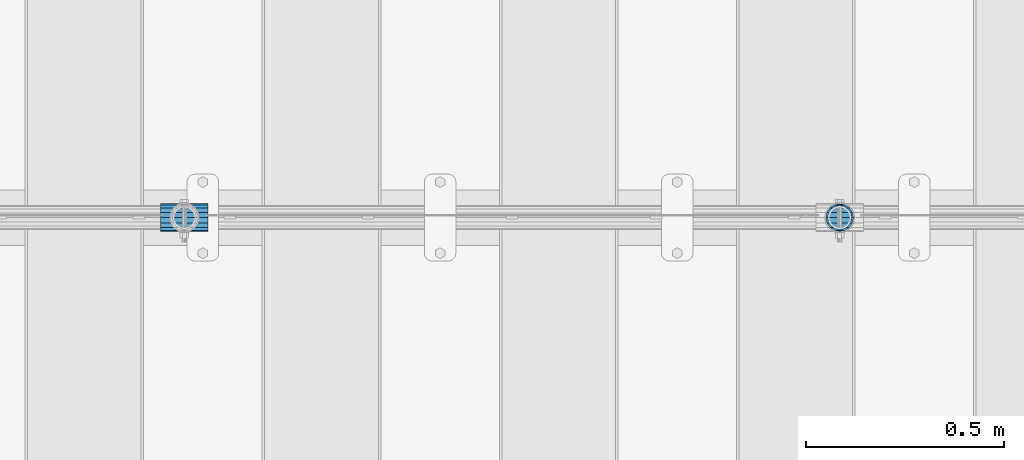
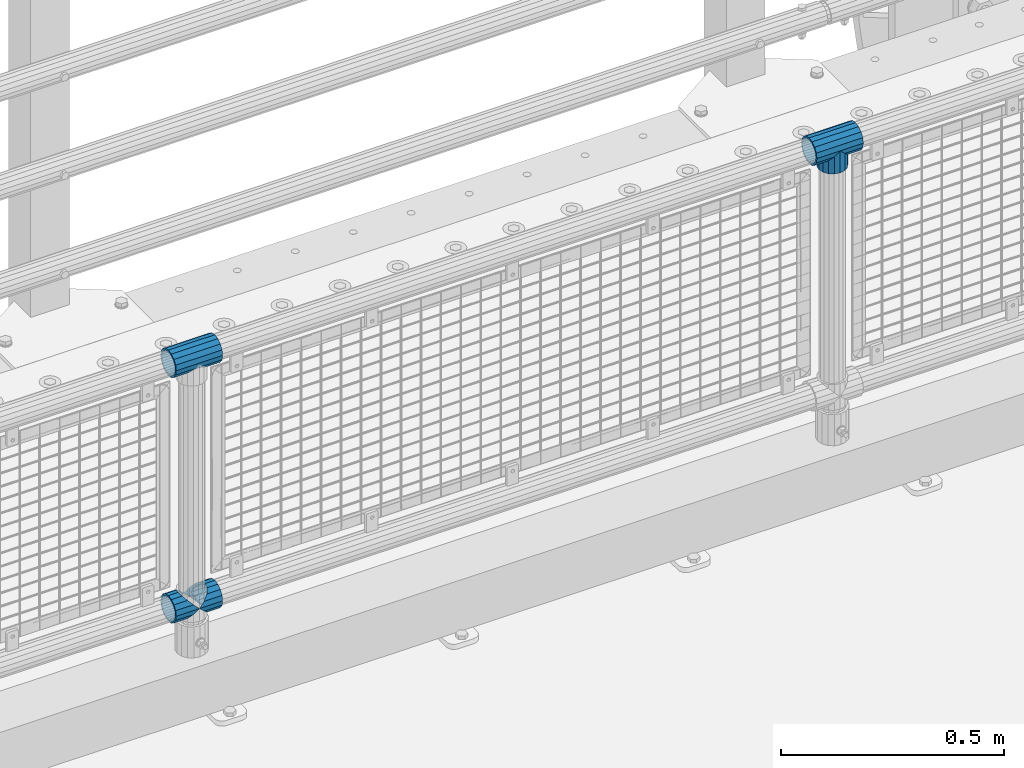
# One storey, part 153 of 240: 5 beams.
"""IFC2X3 building model written with IfcOpenShell, lengths in millimetres."""

from ifc_helpers import new_model, si_unit, frame, origin_with_axes, place, context, subcontext, project, spatial, faceted_brep, material, type_object, element, save


model = new_model("IFC2X3")

# Units and contexts
model_context = context("Model", 3, precision=1e-05, world=origin_with_axes())
body_context = subcontext(model_context, "Body", "Model", "MODEL_VIEW")
ifc_project = project(units=[si_unit("LENGTHUNIT", "METRE", prefix="MILLI"), si_unit("AREAUNIT", "SQUARE_METRE"), si_unit("VOLUMEUNIT", "CUBIC_METRE"), si_unit("MASSUNIT", "GRAM", prefix="KILO"), si_unit("TIMEUNIT", "SECOND"), si_unit("PLANEANGLEUNIT", "RADIAN"), si_unit("SOLIDANGLEUNIT", "STERADIAN"), si_unit("THERMODYNAMICTEMPERATUREUNIT", "DEGREE_CELSIUS"), si_unit("LUMINOUSINTENSITYUNIT", "LUMEN")], contexts=[model_context])

# Site, building, storey
site_placement = place(None, origin_with_axes())
site = spatial("IfcSite", under=ifc_project, at=site_placement, CompositionType="ELEMENT")
building_placement = place(site_placement, origin_with_axes())
building = spatial("IfcBuilding", under=site, at=building_placement, Name="Standard", CompositionType="ELEMENT")
storey_placement = place(building_placement, origin_with_axes())
storey = spatial("IfcBuildingStorey", under=building, at=storey_placement, Name="Undefined", CompositionType="ELEMENT", Elevation=0.0)

# Beams
ifc_material = material(Name="Misc_Undefined")
beam_type = type_object("IfcBeamType", PredefinedType="NOTDEFINED")
beam_1_placement = place(storey_placement, frame((51361.0, 34664.5, 969.849999999999), z_axis=(0.0, 1.0, 0.0), x_axis=(0.0, 0.0, -1.0)))
element("IfcBeam", 1, at=beam_1_placement, inside=storey, type_object=beam_type, material=ifc_material, context=body_context, shape_type="Brep", body=[
    faceted_brep([(0.0, 0.0, 35.1500000000015), (13.4513226476338, 13.4513226476329, 32.4743655677739), (13.4513226476338, -13.4513226476329, 32.4743655677739), (24.8548033587067, -16.3810424079947, -24.8548033587067), (24.8548033587067, -24.8548033587072, -24.8548033587067), (32.4743655677739, -32.4743655677717, -13.4513226476338), (32.4743655677739, -26.8123795176712, -13.4513226476338), (27.1226768591223, -21.4606908090117, -21.4606908090136), (0.0, 0.0, -35.1500000000015), (13.4513226476338, -13.4513226476329, -32.4743655677739), (13.4513226476338, 13.4513226476329, -32.4743655677739), (20.0882031229994, -11.6144421722805, -28.0397438117143), (16.6306603983758, 0.0, -30.3499999999985), (20.0882031229994, 11.6144421722805, -28.0397438117143), (24.8548033587067, 16.3810424080013, -24.8548033587067), (24.8548033587067, 24.8548033587072, -24.8548033587067), (27.1226768591223, 21.4606908090117, -21.4606908090136), (32.4743655677739, 26.8123795176712, -13.4513226476338), (32.4743655677739, 32.4743655677717, -13.4513226476338), (32.8397438117172, 28.0397438117175, -11.6144421722784), (35.1500000000015, 30.35, 0.0), (35.1500000000015, 35.15, 0.0), (32.8397438117099, 28.0397438117175, 11.6144421722784), (32.4743655677739, 26.8123795176755, 13.4513226476338), (32.4743655677739, 32.4743655677717, 13.4513226476338), (27.1226768591005, 21.4606908090117, 21.4606908090136), (24.8548033587067, 16.3810424080013, 24.8548033587067), (24.8548033587067, 24.8548033587072, 24.8548033587067), (20.0882031229849, 11.6144421722805, 28.0397438117143), (16.6306603983685, 0.0, 30.3499999999985), (20.0882031229849, -11.6144421722805, 28.0397438117143), (24.8548033587067, -16.3810424080078, 24.8548033587067), (24.8548033587067, -24.8548033587072, 24.8548033587067), (27.1226768591005, -21.4606908090117, 21.4606908090136), (32.4743655677739, -26.8123795176712, 13.4513226476338), (32.4743655677739, -32.4743655677717, 13.4513226476338), (32.8397438117099, -28.0397438117175, 11.6144421722784), (35.1500000000015, -30.35, 0.0), (35.1500000000015, -35.15, 0.0), (32.8397438117172, -28.0397438117175, -11.6144421722784), (60.1500000000015, -24.8548033587072, -24.8548033587067), (60.1500000000015, -32.4743655677717, -13.4513226476338), (60.1500000000015, -13.4513226476329, -32.4743655677739), (60.1500000000015, 0.0, -35.1500000000015), (60.1500000000015, 13.4513226476329, -32.4743655677739), (60.1500000000015, 24.8548033587072, -24.8548033587067), (60.1500000000015, 32.4743655677717, -13.4513226476338), (60.1500000000015, 35.15, 0.0), (60.1500000000015, 32.4743655677717, 13.4513226476338), (60.1500000000015, 24.8548033587072, 24.8548033587067), (60.1500000000015, 13.4513226476329, 32.4743655677739), (60.1500000000015, 0.0, 35.1500000000015), (60.1500000000015, -13.4513226476329, 32.4743655677739), (60.1500000000015, -24.8548033587072, 24.8548033587067), (60.1500000000015, -32.4743655677717, 13.4513226476338), (60.1500000000015, -35.15, 0.0), (60.1500000000015, -21.4606908090117, 21.4606908090136), (60.1500000000015, -11.6144421722805, 28.0397438117143), (60.1500000000015, 0.0, 30.3499999999985), (60.1500000000015, 11.6144421722805, 28.0397438117143), (60.1500000000015, 21.4606908090117, 21.4606908090136), (60.1500000000015, 28.0397438117175, 11.6144421722784), (60.1500000000015, 30.35, 0.0), (60.1500000000015, 28.0397438117175, -11.6144421722784), (60.1500000000015, 21.4606908090117, -21.4606908090136), (60.1500000000015, 11.6144421722805, -28.0397438117143), (60.1500000000015, 0.0, -30.3499999999985), (60.1500000000015, -11.6144421722805, -28.0397438117143), (60.1500000000015, -21.4606908090117, -21.4606908090136), (60.1500000000015, -28.0397438117175, -11.6144421722784), (60.1500000000015, -30.35, 0.0), (60.1500000000015, -28.0397438117175, 11.6144421722784)], [[[0, 1, 2]], [[3, 4, 5, 6, 7]], [[8, 9, 10]], [[10, 9, 4, 3, 11, 12, 13, 14, 15]], [[15, 14, 16, 17, 18]], [[18, 17, 19, 20, 21]], [[21, 20, 22, 23, 24]], [[24, 23, 25, 26, 27]], [[27, 26, 28, 29, 30, 31, 32, 2, 1]], [[33, 34, 35, 32, 31]], [[36, 37, 38, 35, 34]], [[6, 5, 38, 37, 39]], [[40, 41, 5, 4]], [[42, 40, 4, 9]], [[43, 42, 9, 8]], [[44, 43, 8, 10]], [[45, 44, 10, 15]], [[46, 45, 15, 18]], [[47, 46, 18, 21]], [[48, 47, 21, 24]], [[49, 48, 24, 27]], [[50, 49, 27, 1]], [[51, 50, 1, 0]], [[52, 51, 0, 2]], [[53, 52, 2, 32]], [[54, 53, 32, 35]], [[55, 54, 35, 38]], [[41, 55, 38, 5]], [[40, 42, 43, 44, 45, 46, 47, 48, 49, 50, 51, 52, 53, 54, 55, 41], [56, 57, 58, 59, 60, 61, 62, 63, 64, 65, 66, 67, 68, 69, 70, 71]], [[71, 70, 37, 36]], [[56, 71, 36, 34, 33]], [[57, 56, 33, 31, 30]], [[58, 57, 30, 29]], [[59, 58, 29, 28]], [[25, 60, 59, 28, 26]], [[22, 61, 60, 25, 23]], [[62, 61, 22, 20]], [[63, 62, 20, 19]], [[64, 63, 19, 17, 16]], [[65, 64, 16, 14, 13]], [[66, 65, 13, 12]], [[67, 66, 12, 11]], [[7, 68, 67, 11, 3]], [[39, 69, 68, 7, 6]], [[70, 69, 39, 37]]]),
])
beam_2_placement = place(storey_placement, frame((51300.85, 34664.5, 969.849999999999), z_axis=(0.0, 0.0, 1.0), x_axis=(1.0, 0.0, 0.0)))
element("IfcBeam", 2, at=beam_2_placement, inside=storey, type_object=beam_type, material=ifc_material, context=body_context, shape_type="Brep", body=[
    faceted_brep([(88.1897438117157, -11.6144421722784, -28.0397438117176), (88.1897438117157, -11.6144421722784, -32.8397438117188), (86.962379517674, -13.4513226476338, -32.4743655677718), (81.6106908090151, -21.4606908090136, -27.1226768591079), (81.6106908090151, -21.4606908090136, -21.4606908090117), (76.5310424080089, -24.8548033587067, -24.8548033587072), (71.7644421722798, -28.0397438117143, -20.0882031229927), (71.7644421722798, -28.0397438117143, -11.6144421722805), (60.1500000000015, -30.3499999999985, -16.6306603983737), (60.1500000000015, -30.35, 0.0), (48.5355578277231, -28.0397438117143, -20.0882031229927), (48.5355578277231, -28.0397438117143, -11.6144421722805), (43.7689575920012, -24.8548033587067, -24.8548033587072), (38.6893091909878, -21.4606908090136, -27.1226768591079), (38.6893091909878, -21.4606908090136, -21.4606908090117), (33.3376204823217, -13.4513226476338, -32.4743655677718), (32.1102561882872, -11.6144421722784, -32.8397438117188), (32.1102561882872, -11.6144421722784, -28.0397438117176), (29.8000000000029, 0.0, -35.15), (29.8000000000029, 0.0, -30.35), (32.1102561882872, 11.6144421722784, -32.8397438117188), (32.1102561882872, 11.6144421722784, -28.0397438117176), (33.3376204823362, 13.4513226476338, -32.4743655677718), (38.6893091909878, 21.4606908090136, -27.1226768591079), (38.6893091909878, 21.4606908090136, -21.4606908090117), (43.7689575919867, 24.8548033587067, -24.8548033587072), (48.5355578277231, 28.0397438117143, -20.0882031229927), (48.5355578277231, 28.0397438117143, -11.6144421722805), (60.1500000000015, 30.3499999999985, -16.6306603983737), (60.1500000000015, 30.35, 0.0), (71.7644421722798, 28.0397438117143, -20.0882031229927), (71.7644421722798, 28.0397438117143, -11.6144421722805), (76.5310424080017, 24.8548033587067, -24.8548033587072), (81.6106908090151, 21.4606908090136, -27.1226768591079), (81.6106908090151, 21.4606908090136, -21.4606908090117), (86.962379517674, 13.4513226476338, -32.4743655677718), (88.1897438117157, 11.6144421722784, -32.8397438117188), (88.1897438117157, 11.6144421722784, -28.0397438117176), (90.5, 0.0, -35.15), (90.5, 0.0, -30.35), (0.0, -21.4606908090136, -21.4606908090136), (0.0, -28.0397438117143, -11.6144421722784), (0.0, -11.6144421722784, -28.0397438117143), (0.0, 0.0, -30.3499999999985), (0.0, 11.6144421722784, -28.0397438117143), (0.0, 21.4606908090136, -21.4606908090136), (0.0, 28.0397438117143, -11.6144421722784), (0.0, 30.3499999999985, 0.0), (0.0, 32.4743655677739, -13.4513226476338), (0.0, 35.1500000000015, 0.0), (120.300000000003, 35.1500000000015, 0.0), (120.300000000003, 32.4743655677739, -13.4513226476329), (0.0, 32.4743655677739, 13.4513226476338), (120.300000000003, 32.4743655677739, 13.4513226476329), (0.0, 24.8548033587067, 24.8548033587067), (120.300000000003, 24.8548033587067, 24.8548033587072), (0.0, 13.4513226476338, 32.4743655677739), (120.300000000003, 13.4513226476338, 32.4743655677718), (0.0, 0.0, 35.1500000000015), (120.300000000003, 0.0, 35.15), (0.0, -13.4513226476338, 32.4743655677739), (120.300000000003, -13.4513226476338, 32.4743655677718), (0.0, -24.8548033587067, 24.8548033587067), (120.300000000003, -24.8548033587067, 24.8548033587072), (0.0, -32.4743655677739, 13.4513226476338), (120.300000000003, -32.4743655677739, 13.4513226476329), (0.0, -35.1500000000015, 0.0), (120.300000000003, -35.1500000000015, 0.0), (0.0, -32.4743655677739, -13.4513226476338), (120.300000000003, -32.4743655677739, -13.4513226476329), (0.0, 24.8548033587067, -24.8548033587067), (0.0, 13.4513226476338, -32.4743655677739), (0.0, 0.0, -35.1500000000015), (0.0, -13.4513226476338, -32.4743655677739), (0.0, -24.8548033587067, -24.8548033587067), (0.0, 28.0397438117143, 11.6144421722784), (0.0, 21.4606908090136, 21.4606908090136), (0.0, 11.6144421722784, 28.0397438117143), (0.0, 0.0, 30.3499999999985), (0.0, -11.6144421722784, 28.0397438117143), (0.0, -21.4606908090136, 21.4606908090136), (0.0, -28.0397438117143, 11.6144421722784), (0.0, -30.3499999999985, 0.0), (120.300000000003, -30.3499999999985, 0.0), (120.300000000003, -28.0397438117143, -11.6144421722805), (120.300000000003, -21.4606908090136, -21.4606908090117), (120.300000000003, -11.6144421722784, -28.0397438117176), (120.300000000003, 0.0, -30.35), (120.300000000003, 21.4606908090136, -21.4606908090117), (120.300000000003, 28.0397438117143, -11.6144421722805), (120.300000000003, 11.6144421722784, -28.0397438117176), (120.300000000003, 30.3499999999985, 0.0), (120.300000000003, 28.0397438117143, 11.6144421722805), (120.300000000003, 21.4606908090136, 21.4606908090117), (120.300000000003, 11.6144421722784, 28.0397438117176), (120.300000000003, 0.0, 30.35), (120.300000000003, -11.6144421722784, 28.0397438117176), (120.300000000003, -21.4606908090136, 21.4606908090117), (120.300000000003, -28.0397438117143, 11.6144421722805), (120.300000000003, -24.8548033587067, -24.8548033587072), (120.300000000003, -13.4513226476338, -32.4743655677718), (120.300000000003, 0.0, -35.15), (120.300000000003, 13.4513226476338, -32.4743655677718), (120.300000000003, 24.8548033587067, -24.8548033587072)], [[[0, 1, 2, 3, 4]], [[4, 3, 5, 6, 7]], [[7, 6, 8, 9]], [[9, 8, 10, 11]], [[11, 10, 12, 13, 14]], [[14, 13, 15, 16, 17]], [[17, 16, 18, 19]], [[19, 18, 20, 21]], [[21, 20, 22, 23, 24]], [[24, 23, 25, 26, 27]], [[27, 26, 28, 29]], [[29, 28, 30, 31]], [[31, 30, 32, 33, 34]], [[34, 33, 35, 36, 37]], [[37, 36, 38, 39]], [[39, 38, 1, 0]], [[40, 41, 11, 14]], [[42, 40, 14, 17]], [[43, 42, 17, 19]], [[44, 43, 19, 21]], [[45, 44, 21, 24]], [[46, 45, 24, 27]], [[47, 46, 27, 29]], [[48, 49, 50, 51]], [[49, 52, 53, 50]], [[52, 54, 55, 53]], [[54, 56, 57, 55]], [[56, 58, 59, 57]], [[58, 60, 61, 59]], [[60, 62, 63, 61]], [[62, 64, 65, 63]], [[64, 66, 67, 65]], [[66, 68, 69, 67]], [[64, 62, 60, 58, 56, 54, 52, 49, 48, 70, 71, 72, 73, 74, 68, 66], [41, 40, 42, 43, 44, 45, 46, 47, 75, 76, 77, 78, 79, 80, 81, 82]], [[41, 82, 9, 11]], [[83, 84, 7, 9]], [[84, 85, 4, 7]], [[85, 86, 0, 4]], [[86, 87, 39, 0]], [[88, 89, 31, 34]], [[90, 88, 34, 37]], [[87, 90, 37, 39]], [[89, 91, 29, 31]], [[75, 47, 29, 91, 92]], [[76, 75, 92, 93]], [[77, 76, 93, 94]], [[78, 77, 94, 95]], [[79, 78, 95, 96]], [[80, 79, 96, 97]], [[81, 80, 97, 98]], [[9, 82, 81, 98, 83]], [[99, 100, 101, 102, 103, 51, 50, 53, 55, 57, 59, 61, 63, 65, 67, 69], [97, 96, 95, 94, 93, 92, 91, 89, 88, 90, 87, 86, 85, 84, 83, 98]], [[35, 102, 101, 38, 36]], [[32, 103, 102, 35, 33]], [[28, 26, 25, 70, 48, 51, 103, 32, 30]], [[22, 71, 70, 25, 23]], [[18, 72, 71, 22, 20]], [[73, 72, 18, 16, 15]], [[74, 73, 15, 13, 12]], [[99, 69, 68, 74, 12, 10, 8, 6, 5]], [[100, 99, 5, 3, 2]], [[101, 100, 2, 1, 38]]]),
])
beam_3_placement = place(storey_placement, frame((49642.85, 34664.5, 969.849999999999), z_axis=(0.0, 0.0, 1.0), x_axis=(1.0, 0.0, 0.0)))
element("IfcBeam", 3, at=beam_3_placement, inside=storey, type_object=beam_type, material=ifc_material, context=body_context, shape_type="Brep", body=[
    faceted_brep([(88.1897438117157, -11.6144421722784, -28.0397438117176), (88.1897438117157, -11.6144421722784, -32.8397438117188), (86.962379517674, -13.4513226476338, -32.4743655677718), (81.6106908090151, -21.4606908090136, -27.1226768591079), (81.6106908090151, -21.4606908090136, -21.4606908090117), (76.5310424080089, -24.8548033587067, -24.8548033587072), (71.7644421722798, -28.0397438117143, -20.0882031229927), (71.7644421722798, -28.0397438117143, -11.6144421722805), (60.1500000000015, -30.3499999999985, -16.6306603983737), (60.1500000000015, -30.35, 0.0), (48.5355578277231, -28.0397438117143, -20.0882031229927), (48.5355578277231, -28.0397438117143, -11.6144421722805), (43.7689575920012, -24.8548033587067, -24.8548033587072), (38.6893091909878, -21.4606908090136, -27.1226768591079), (38.6893091909878, -21.4606908090136, -21.4606908090117), (33.3376204823217, -13.4513226476338, -32.4743655677718), (32.1102561882872, -11.6144421722784, -32.8397438117188), (32.1102561882872, -11.6144421722784, -28.0397438117176), (29.8000000000029, 0.0, -35.15), (29.8000000000029, 0.0, -30.35), (32.1102561882872, 11.6144421722784, -32.8397438117188), (32.1102561882872, 11.6144421722784, -28.0397438117176), (33.3376204823362, 13.4513226476338, -32.4743655677718), (38.6893091909878, 21.4606908090136, -27.1226768591079), (38.6893091909878, 21.4606908090136, -21.4606908090117), (43.7689575919867, 24.8548033587067, -24.8548033587072), (48.5355578277231, 28.0397438117143, -20.0882031229927), (48.5355578277231, 28.0397438117143, -11.6144421722805), (60.1500000000015, 30.3499999999985, -16.6306603983737), (60.1500000000015, 30.35, 0.0), (71.7644421722798, 28.0397438117143, -20.0882031229927), (71.7644421722798, 28.0397438117143, -11.6144421722805), (76.5310424080017, 24.8548033587067, -24.8548033587072), (81.6106908090151, 21.4606908090136, -27.1226768591079), (81.6106908090151, 21.4606908090136, -21.4606908090117), (86.962379517674, 13.4513226476338, -32.4743655677718), (88.1897438117157, 11.6144421722784, -32.8397438117188), (88.1897438117157, 11.6144421722784, -28.0397438117176), (90.5, 0.0, -35.15), (90.5, 0.0, -30.35), (0.0, -21.4606908090136, -21.4606908090136), (0.0, -28.0397438117143, -11.6144421722784), (0.0, -11.6144421722784, -28.0397438117143), (0.0, 0.0, -30.3499999999985), (0.0, 11.6144421722784, -28.0397438117143), (0.0, 21.4606908090136, -21.4606908090136), (0.0, 28.0397438117143, -11.6144421722784), (0.0, 30.3499999999985, 0.0), (0.0, 32.4743655677739, -13.4513226476338), (0.0, 35.1500000000015, 0.0), (120.300000000003, 35.1500000000015, 0.0), (120.300000000003, 32.4743655677739, -13.4513226476329), (0.0, 32.4743655677739, 13.4513226476338), (120.300000000003, 32.4743655677739, 13.4513226476329), (0.0, 24.8548033587067, 24.8548033587067), (120.300000000003, 24.8548033587067, 24.8548033587072), (0.0, 13.4513226476338, 32.4743655677739), (120.300000000003, 13.4513226476338, 32.4743655677718), (0.0, 0.0, 35.1500000000015), (120.300000000003, 0.0, 35.15), (0.0, -13.4513226476338, 32.4743655677739), (120.300000000003, -13.4513226476338, 32.4743655677718), (0.0, -24.8548033587067, 24.8548033587067), (120.300000000003, -24.8548033587067, 24.8548033587072), (0.0, -32.4743655677739, 13.4513226476338), (120.300000000003, -32.4743655677739, 13.4513226476329), (0.0, -35.1500000000015, 0.0), (120.300000000003, -35.1500000000015, 0.0), (0.0, -32.4743655677739, -13.4513226476338), (120.300000000003, -32.4743655677739, -13.4513226476329), (0.0, 24.8548033587067, -24.8548033587067), (0.0, 13.4513226476338, -32.4743655677739), (0.0, 0.0, -35.1500000000015), (0.0, -13.4513226476338, -32.4743655677739), (0.0, -24.8548033587067, -24.8548033587067), (0.0, 28.0397438117143, 11.6144421722784), (0.0, 21.4606908090136, 21.4606908090136), (0.0, 11.6144421722784, 28.0397438117143), (0.0, 0.0, 30.3499999999985), (0.0, -11.6144421722784, 28.0397438117143), (0.0, -21.4606908090136, 21.4606908090136), (0.0, -28.0397438117143, 11.6144421722784), (0.0, -30.3499999999985, 0.0), (120.300000000003, -30.3499999999985, 0.0), (120.300000000003, -28.0397438117143, -11.6144421722805), (120.300000000003, -21.4606908090136, -21.4606908090117), (120.300000000003, -11.6144421722784, -28.0397438117176), (120.300000000003, 0.0, -30.35), (120.300000000003, 21.4606908090136, -21.4606908090117), (120.300000000003, 28.0397438117143, -11.6144421722805), (120.300000000003, 11.6144421722784, -28.0397438117176), (120.300000000003, 30.3499999999985, 0.0), (120.300000000003, 28.0397438117143, 11.6144421722805), (120.300000000003, 21.4606908090136, 21.4606908090117), (120.300000000003, 11.6144421722784, 28.0397438117176), (120.300000000003, 0.0, 30.35), (120.300000000003, -11.6144421722784, 28.0397438117176), (120.300000000003, -21.4606908090136, 21.4606908090117), (120.300000000003, -28.0397438117143, 11.6144421722805), (120.300000000003, -24.8548033587067, -24.8548033587072), (120.300000000003, -13.4513226476338, -32.4743655677718), (120.300000000003, 0.0, -35.15), (120.300000000003, 13.4513226476338, -32.4743655677718), (120.300000000003, 24.8548033587067, -24.8548033587072)], [[[0, 1, 2, 3, 4]], [[4, 3, 5, 6, 7]], [[7, 6, 8, 9]], [[9, 8, 10, 11]], [[11, 10, 12, 13, 14]], [[14, 13, 15, 16, 17]], [[17, 16, 18, 19]], [[19, 18, 20, 21]], [[21, 20, 22, 23, 24]], [[24, 23, 25, 26, 27]], [[27, 26, 28, 29]], [[29, 28, 30, 31]], [[31, 30, 32, 33, 34]], [[34, 33, 35, 36, 37]], [[37, 36, 38, 39]], [[39, 38, 1, 0]], [[40, 41, 11, 14]], [[42, 40, 14, 17]], [[43, 42, 17, 19]], [[44, 43, 19, 21]], [[45, 44, 21, 24]], [[46, 45, 24, 27]], [[47, 46, 27, 29]], [[48, 49, 50, 51]], [[49, 52, 53, 50]], [[52, 54, 55, 53]], [[54, 56, 57, 55]], [[56, 58, 59, 57]], [[58, 60, 61, 59]], [[60, 62, 63, 61]], [[62, 64, 65, 63]], [[64, 66, 67, 65]], [[66, 68, 69, 67]], [[64, 62, 60, 58, 56, 54, 52, 49, 48, 70, 71, 72, 73, 74, 68, 66], [41, 40, 42, 43, 44, 45, 46, 47, 75, 76, 77, 78, 79, 80, 81, 82]], [[41, 82, 9, 11]], [[83, 84, 7, 9]], [[84, 85, 4, 7]], [[85, 86, 0, 4]], [[86, 87, 39, 0]], [[88, 89, 31, 34]], [[90, 88, 34, 37]], [[87, 90, 37, 39]], [[89, 91, 29, 31]], [[75, 47, 29, 91, 92]], [[76, 75, 92, 93]], [[77, 76, 93, 94]], [[78, 77, 94, 95]], [[79, 78, 95, 96]], [[80, 79, 96, 97]], [[81, 80, 97, 98]], [[9, 82, 81, 98, 83]], [[99, 100, 101, 102, 103, 51, 50, 53, 55, 57, 59, 61, 63, 65, 67, 69], [97, 96, 95, 94, 93, 92, 91, 89, 88, 90, 87, 86, 85, 84, 83, 98]], [[35, 102, 101, 38, 36]], [[32, 103, 102, 35, 33]], [[28, 26, 25, 70, 48, 51, 103, 32, 30]], [[22, 71, 70, 25, 23]], [[18, 72, 71, 22, 20]], [[73, 72, 18, 16, 15]], [[74, 73, 15, 13, 12]], [[99, 69, 68, 74, 12, 10, 8, 6, 5]], [[100, 99, 5, 3, 2]], [[101, 100, 2, 1, 38]]]),
])
beam_4_placement = place(storey_placement, frame((49642.85, 34664.5, 298.17), z_axis=(0.0, 1.0, 0.0), x_axis=(1.0, 0.0, 0.0)))
element("IfcBeam", 4, at=beam_4_placement, inside=storey, type_object=beam_type, material=ifc_material, context=body_context, shape_type="Brep", body=[
    faceted_brep([(60.1500000000015, 0.0, -35.1500000000015), (46.6986773523677, 13.4513226476329, -32.4743655677739), (46.6986773523677, -13.4513226476329, -32.4743655677739), (33.0273231408937, 21.4606908090117, 21.4606908090136), (27.6756344322275, 26.8123795176712, 13.4513226476338), (27.6756344322275, 32.4743655677717, 13.4513226476338), (35.2951966412948, 24.8548033587072, 24.8548033587067), (35.2951966412948, 16.3810424080013, 24.8548033587067), (27.3102561882843, 28.0397438117175, 11.6144421722784), (25.0, 30.35, 0.0), (25.0, 35.15, 0.0), (27.6756344322275, 26.8123795176712, -13.4513226476338), (27.6756344322275, 32.4743655677717, -13.4513226476338), (27.3102561882843, 28.0397438117175, -11.6144421722784), (35.2951966412948, 16.3810424080078, -24.8548033587067), (35.2951966412948, 24.8548033587072, -24.8548033587067), (33.0273231408937, 21.4606908090117, -21.4606908090136), (40.0617968770021, 11.6144421722805, -28.0397438117143), (43.5193396016257, 0.0, -30.3499999999985), (40.0617968770021, -11.6144421722805, -28.0397438117143), (35.2951966412948, -16.3810424079948, -24.8548033587067), (35.2951966412948, -24.8548033587072, -24.8548033587067), (33.0273231408937, -21.4606908090117, -21.4606908090136), (27.6756344322275, -26.8123795176755, -13.4513226476338), (27.6756344322275, -32.4743655677717, -13.4513226476338), (27.3102561882843, -28.0397438117175, -11.6144421722784), (25.0, -30.35, 0.0), (25.0, -35.15, 0.0), (27.3102561882843, -28.0397438117175, 11.6144421722784), (27.6756344322275, -26.8123795176712, 13.4513226476338), (27.6756344322275, -32.4743655677717, 13.4513226476338), (33.0273231408937, -21.4606908090117, 21.4606908090136), (35.2951966412948, -16.3810424080078, 24.8548033587067), (35.2951966412948, -24.8548033587072, 24.8548033587067), (60.1500000000015, 0.0, 35.1500000000015), (46.6986773523677, -13.4513226476329, 32.4743655677739), (46.6986773523677, 13.4513226476329, 32.4743655677739), (40.0617968770093, -11.6144421722805, 28.0397438117143), (43.5193396016257, 0.0, 30.3499999999985), (40.0617968770093, 11.6144421722805, 28.0397438117143), (0.0, -32.4743655677739, -13.4513226476338), (0.0, -24.8548033587067, -24.8548033587067), (0.0, -13.4513226476338, -32.4743655677739), (0.0, 0.0, -35.1500000000015), (0.0, 13.4513226476338, -32.4743655677739), (0.0, 24.8548033587067, -24.8548033587067), (0.0, 32.4743655677739, -13.4513226476338), (0.0, 35.1500000000015, 0.0), (0.0, 32.4743655677739, 13.4513226476338), (0.0, 24.8548033587067, 24.8548033587067), (0.0, 13.4513226476338, 32.4743655677739), (0.0, 0.0, 35.1500000000015), (0.0, -32.4743655677739, 13.4513226476338), (0.0, -35.1500000000015, 0.0), (0.0, -24.8548033587067, 24.8548033587067), (0.0, -13.4513226476338, 32.4743655677739), (0.0, -28.0397438117143, -11.6144421722784), (0.0, -21.4606908090136, -21.4606908090136), (0.0, -11.6144421722784, -28.0397438117143), (0.0, 0.0, -30.3499999999985), (0.0, 11.6144421722784, -28.0397438117143), (0.0, 21.4606908090136, -21.4606908090136), (0.0, 28.0397438117143, -11.6144421722784), (0.0, 30.3499999999985, 0.0), (0.0, 28.0397438117143, 11.6144421722784), (0.0, 21.4606908090136, 21.4606908090136), (0.0, 11.6144421722784, 28.0397438117143), (0.0, 0.0, 30.3499999999985), (0.0, -11.6144421722784, 28.0397438117143), (0.0, -21.4606908090136, 21.4606908090136), (0.0, -28.0397438117143, 11.6144421722784), (0.0, -30.3499999999985, 0.0)], [[[0, 1, 2]], [[3, 4, 5, 6, 7]], [[8, 9, 10, 5, 4]], [[11, 12, 10, 9, 13]], [[14, 15, 12, 11, 16]], [[2, 1, 15, 14, 17, 18, 19, 20, 21]], [[21, 20, 22, 23, 24]], [[24, 23, 25, 26, 27]], [[27, 26, 28, 29, 30]], [[30, 29, 31, 32, 33]], [[34, 35, 36]], [[33, 32, 37, 38, 39, 7, 6, 36, 35]], [[40, 41, 21, 24]], [[41, 42, 2, 21]], [[42, 43, 0, 2]], [[43, 44, 1, 0]], [[44, 45, 15, 1]], [[45, 46, 12, 15]], [[46, 47, 10, 12]], [[47, 48, 5, 10]], [[48, 49, 6, 5]], [[49, 50, 36, 6]], [[50, 51, 34, 36]], [[52, 53, 27, 30]], [[54, 52, 30, 33]], [[55, 54, 33, 35]], [[51, 55, 35, 34]], [[53, 40, 24, 27]], [[52, 54, 55, 51, 50, 49, 48, 47, 46, 45, 44, 43, 42, 41, 40, 53], [56, 57, 58, 59, 60, 61, 62, 63, 64, 65, 66, 67, 68, 69, 70, 71]], [[68, 67, 38, 37]], [[31, 69, 68, 37, 32]], [[28, 70, 69, 31, 29]], [[71, 70, 28, 26]], [[56, 71, 26, 25]], [[57, 56, 25, 23, 22]], [[58, 57, 22, 20, 19]], [[59, 58, 19, 18]], [[60, 59, 18, 17]], [[16, 61, 60, 17, 14]], [[13, 62, 61, 16, 11]], [[63, 62, 13, 9]], [[64, 63, 9, 8]], [[65, 64, 8, 4, 3]], [[66, 65, 3, 7, 39]], [[67, 66, 39, 38]]]),
])
beam_5_placement = place(storey_placement, frame((49703.0, 34664.5, 298.17), z_axis=(0.0, 1.0, 0.0), x_axis=(1.0, 0.0, 0.0)))
element("IfcBeam", 5, at=beam_5_placement, inside=storey, type_object=beam_type, material=ifc_material, context=body_context, shape_type="Brep", body=[
    faceted_brep([(0.0, 0.0, 35.1500000000015), (13.4513226476338, 13.4513226476329, 32.4743655677739), (13.4513226476338, -13.4513226476329, 32.4743655677739), (24.8548033587067, -16.3810424079947, -24.8548033587067), (24.8548033587067, -24.8548033587072, -24.8548033587067), (32.4743655677739, -32.4743655677717, -13.4513226476338), (32.4743655677739, -26.8123795176712, -13.4513226476338), (27.1226768591223, -21.4606908090117, -21.4606908090136), (0.0, 0.0, -35.1500000000015), (13.4513226476338, -13.4513226476329, -32.4743655677739), (13.4513226476338, 13.4513226476329, -32.4743655677739), (20.0882031229994, -11.6144421722805, -28.0397438117143), (16.6306603983758, 0.0, -30.3499999999985), (20.0882031229994, 11.6144421722805, -28.0397438117143), (24.8548033587067, 16.3810424080013, -24.8548033587067), (24.8548033587067, 24.8548033587072, -24.8548033587067), (27.1226768591223, 21.4606908090117, -21.4606908090136), (32.4743655677739, 26.8123795176712, -13.4513226476338), (32.4743655677739, 32.4743655677717, -13.4513226476338), (32.8397438117172, 28.0397438117175, -11.6144421722784), (35.1500000000015, 30.35, 0.0), (35.1500000000015, 35.15, 0.0), (32.8397438117099, 28.0397438117175, 11.6144421722784), (32.4743655677739, 26.8123795176755, 13.4513226476338), (32.4743655677739, 32.4743655677717, 13.4513226476338), (27.1226768591005, 21.4606908090117, 21.4606908090136), (24.8548033587067, 16.3810424080013, 24.8548033587067), (24.8548033587067, 24.8548033587072, 24.8548033587067), (20.0882031229849, 11.6144421722805, 28.0397438117143), (16.6306603983685, 0.0, 30.3499999999985), (20.0882031229849, -11.6144421722805, 28.0397438117143), (24.8548033587067, -16.3810424080078, 24.8548033587067), (24.8548033587067, -24.8548033587072, 24.8548033587067), (27.1226768591005, -21.4606908090117, 21.4606908090136), (32.4743655677739, -26.8123795176712, 13.4513226476338), (32.4743655677739, -32.4743655677717, 13.4513226476338), (32.8397438117099, -28.0397438117175, 11.6144421722784), (35.1500000000015, -30.35, 0.0), (35.1500000000015, -35.15, 0.0), (32.8397438117172, -28.0397438117175, -11.6144421722784), (60.1500000000015, -24.8548033587072, -24.8548033587067), (60.1500000000015, -32.4743655677717, -13.4513226476338), (60.1500000000015, -13.4513226476329, -32.4743655677739), (60.1500000000015, 0.0, -35.1500000000015), (60.1500000000015, 13.4513226476329, -32.4743655677739), (60.1500000000015, 24.8548033587072, -24.8548033587067), (60.1500000000015, 32.4743655677717, -13.4513226476338), (60.1500000000015, 35.15, 0.0), (60.1500000000015, 32.4743655677717, 13.4513226476338), (60.1500000000015, 24.8548033587072, 24.8548033587067), (60.1500000000015, 13.4513226476329, 32.4743655677739), (60.1500000000015, 0.0, 35.1500000000015), (60.1500000000015, -13.4513226476329, 32.4743655677739), (60.1500000000015, -24.8548033587072, 24.8548033587067), (60.1500000000015, -32.4743655677717, 13.4513226476338), (60.1500000000015, -35.15, 0.0), (60.1500000000015, -21.4606908090117, 21.4606908090136), (60.1500000000015, -11.6144421722805, 28.0397438117143), (60.1500000000015, 0.0, 30.3499999999985), (60.1500000000015, 11.6144421722805, 28.0397438117143), (60.1500000000015, 21.4606908090117, 21.4606908090136), (60.1500000000015, 28.0397438117175, 11.6144421722784), (60.1500000000015, 30.35, 0.0), (60.1500000000015, 28.0397438117175, -11.6144421722784), (60.1500000000015, 21.4606908090117, -21.4606908090136), (60.1500000000015, 11.6144421722805, -28.0397438117143), (60.1500000000015, 0.0, -30.3499999999985), (60.1500000000015, -11.6144421722805, -28.0397438117143), (60.1500000000015, -21.4606908090117, -21.4606908090136), (60.1500000000015, -28.0397438117175, -11.6144421722784), (60.1500000000015, -30.35, 0.0), (60.1500000000015, -28.0397438117175, 11.6144421722784)], [[[0, 1, 2]], [[3, 4, 5, 6, 7]], [[8, 9, 10]], [[10, 9, 4, 3, 11, 12, 13, 14, 15]], [[15, 14, 16, 17, 18]], [[18, 17, 19, 20, 21]], [[21, 20, 22, 23, 24]], [[24, 23, 25, 26, 27]], [[27, 26, 28, 29, 30, 31, 32, 2, 1]], [[33, 34, 35, 32, 31]], [[36, 37, 38, 35, 34]], [[6, 5, 38, 37, 39]], [[40, 41, 5, 4]], [[42, 40, 4, 9]], [[43, 42, 9, 8]], [[44, 43, 8, 10]], [[45, 44, 10, 15]], [[46, 45, 15, 18]], [[47, 46, 18, 21]], [[48, 47, 21, 24]], [[49, 48, 24, 27]], [[50, 49, 27, 1]], [[51, 50, 1, 0]], [[52, 51, 0, 2]], [[53, 52, 2, 32]], [[54, 53, 32, 35]], [[55, 54, 35, 38]], [[41, 55, 38, 5]], [[40, 42, 43, 44, 45, 46, 47, 48, 49, 50, 51, 52, 53, 54, 55, 41], [56, 57, 58, 59, 60, 61, 62, 63, 64, 65, 66, 67, 68, 69, 70, 71]], [[71, 70, 37, 36]], [[56, 71, 36, 34, 33]], [[57, 56, 33, 31, 30]], [[58, 57, 30, 29]], [[59, 58, 29, 28]], [[25, 60, 59, 28, 26]], [[22, 61, 60, 25, 23]], [[62, 61, 22, 20]], [[63, 62, 20, 19]], [[64, 63, 19, 17, 16]], [[65, 64, 16, 14, 13]], [[66, 65, 13, 12]], [[67, 66, 12, 11]], [[7, 68, 67, 11, 3]], [[39, 69, 68, 7, 6]], [[70, 69, 39, 37]]]),
])

save(model, "model.ifc")
